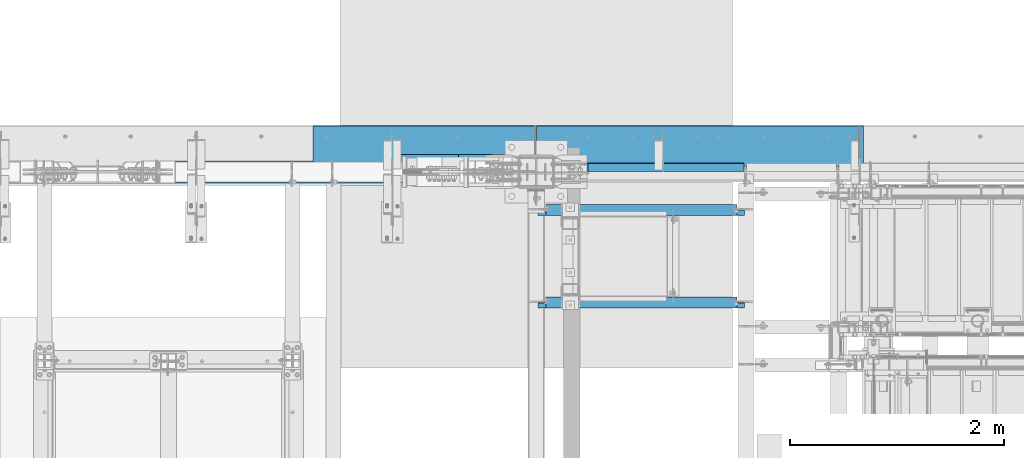
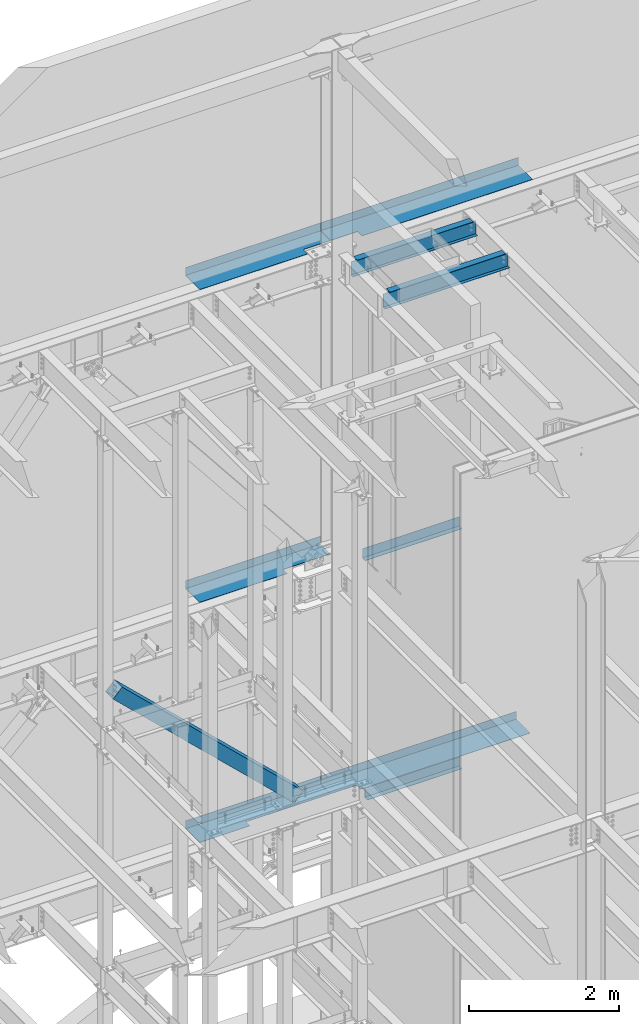
# One storey, part 790 of 1179: 9 beams, 1 member, 9 elements without a shape of their own.
"""IFC2X3 building model written with IfcOpenShell, lengths in millimetres."""

from ifc_helpers import new_model, si_unit, frame, origin_with_axes, place, context, subcontext, project, spatial, faceted_brep, material, type_object, element, aggregate, save


model = new_model("IFC2X3")

# Units and contexts
model_context = context("Model", 3, precision=1e-05, world=origin_with_axes())
body_context = subcontext(model_context, "Body", "Model", "MODEL_VIEW")
ifc_project = project(units=[si_unit("LENGTHUNIT", "METRE", prefix="MILLI"), si_unit("AREAUNIT", "SQUARE_METRE"), si_unit("VOLUMEUNIT", "CUBIC_METRE"), si_unit("MASSUNIT", "GRAM", prefix="KILO"), si_unit("TIMEUNIT", "SECOND"), si_unit("PLANEANGLEUNIT", "RADIAN"), si_unit("SOLIDANGLEUNIT", "STERADIAN"), si_unit("THERMODYNAMICTEMPERATUREUNIT", "DEGREE_CELSIUS"), si_unit("LUMINOUSINTENSITYUNIT", "LUMEN")], contexts=[model_context])

# Site, building, storey
site_placement = place(None, origin_with_axes())
site = spatial("IfcSite", under=ifc_project, at=site_placement, CompositionType="ELEMENT")
building_placement = place(site_placement, origin_with_axes())
building = spatial("IfcBuilding", under=site, at=building_placement, Name="Undefined", CompositionType="ELEMENT")
storey_placement = place(building_placement, origin_with_axes())
storey = spatial("IfcBuildingStorey", under=building, at=storey_placement, Name="Undefined", CompositionType="ELEMENT", Elevation=0.0)

# Assembly, beam
assembly_1_placement = place(storey_placement, origin_with_axes())
assembly_1 = element("IfcElementAssembly", 1, at=assembly_1_placement, inside=storey, Name="BEAM", AssemblyPlace="NOTDEFINED", PredefinedType="RIGID_FRAME")
ifc_material_1 = material(Name="STEEL/A992")
beam_type_1 = type_object("IfcBeamType", Name="W10X12", PredefinedType="NOTDEFINED")
beam_1_placement = place(assembly_1_placement, frame((16459.2, 39979.6, 12993.6875), z_axis=(0.0, 0.0, 1.0), x_axis=(1.0, 0.0, 0.0)))
beam_1 = element("IfcBeam", 2, at=beam_1_placement, type_object=beam_type_1, material=ifc_material_1, Name="BEAM", ObjectType="W10X12", context=body_context, shape_type="Brep", body=[
    faceted_brep([(76.200000190729, -2.38124999999854, 93.6624999999985), (76.200000190729, 2.38123180787079, 93.6624999999985), (15.875, 2.38124999999854, 93.6624999999985), (15.875, -2.38124999999854, 93.6624999999985), (81.0600797087754, -2.38124999999854, 94.6292299225861), (81.0600797087754, 2.38123086899577, 94.6292299225861), (85.1802561769291, -2.38124999999854, 97.3822438230636), (85.1802561769291, 2.38122819529235, 97.3822438230636), (87.9332700774066, -2.38124999999854, 101.502420291217), (87.9332700774066, 2.38122419381398, 101.502420291217), (88.8999999999942, -2.38124999999854, 106.362499809264), (88.8999999999942, 2.38121947374748, 106.362499809264), (88.8999999999942, -50.8000000000029, 125.4125), (88.8999999999942, 50.8000000000029, 125.4125), (88.8999999999942, 50.8000000000029, 120.65), (88.8999999999942, 2.38124999999854, 120.65), (88.8999999999942, -2.38124999999854, 120.65), (88.8999999999942, -50.8000000000029, 120.65), (1812.92500000026, 2.38124999999854, -120.65), (1812.92500000026, 50.8000000000029, -120.65), (142.874999999996, 50.8000000000029, -120.65), (142.874999999996, 2.38174991607229, -120.65), (15.875, -2.38124999999854, -120.65), (15.875, -50.8000000000029, -120.65), (1939.925, -50.8000000000029, -120.65), (1939.925, -2.38124999999854, -120.65), (15.875, -50.8000000000029, -125.4125), (1939.925, -50.8000000000029, -125.4125), (1812.92500000026, 50.8000000000029, -125.4125), (1812.92500000026, 2.38174991607229, -125.4125), (1939.925, 2.38174991607229, -125.4125), (15.875, 2.38174991607229, -125.4125), (142.874999999996, 2.38174991607229, -125.4125), (142.874999999996, 50.8000000000029, -125.4125), (15.875, 2.38124999999854, -120.65), (1939.925, 2.38124999999854, -120.65), (1939.925, 2.38124999999854, 93.6624999999985), (1939.925, -2.38124999999854, 93.6624999999985), (1885.94999980927, 2.38124999999854, 93.6624999999985), (1885.94999980927, -2.38124999999854, 93.6624999999985), (1881.08992029122, 2.38124999999854, 94.6292299225861), (1881.08992029122, -2.38124999999854, 94.6292299225861), (1876.96974382307, 2.38124999999854, 97.3822438230636), (1876.96974382307, -2.38124999999854, 97.3822438230636), (1874.21672992259, 2.38124999999854, 101.502420291217), (1874.21672992259, -2.38124999999854, 101.502420291217), (1873.25, 2.38124999999854, 106.362499809264), (1873.25, -2.38124999999854, 106.362499809264), (1873.25, -50.8000000000029, 125.4125), (1873.25, -50.8000000000029, 120.65), (1873.25, -2.38124999999854, 120.65), (1873.25, 2.38124999999854, 120.65), (1873.25, 50.8000000000029, 120.65), (1873.25, 50.8000000000029, 125.4125)], [[[0, 1, 2, 3]], [[4, 5, 1, 0]], [[6, 7, 5, 4]], [[8, 9, 7, 6]], [[10, 11, 9, 8]], [[12, 13, 14, 15, 11, 10, 16, 17]], [[18, 19, 20, 21]], [[22, 23, 24, 25]], [[23, 26, 27, 24]], [[28, 29, 30, 27, 26, 31, 32, 33]], [[21, 32, 31, 34]], [[20, 33, 32, 21]], [[19, 28, 33, 20]], [[18, 29, 28, 19]], [[35, 30, 29, 18]], [[25, 24, 27, 30, 35, 36, 37]], [[37, 36, 38, 39]], [[39, 38, 40, 41]], [[41, 40, 42, 43]], [[43, 42, 44, 45]], [[45, 44, 46, 47]], [[48, 49, 50, 47, 46, 51, 52, 53]], [[49, 48, 12, 17]], [[50, 49, 17, 16]], [[8, 6, 4, 0, 3, 22, 25, 37, 39, 41, 43, 45, 47, 50, 16, 10]], [[34, 31, 26, 23, 22, 3, 2]], [[51, 46, 44, 42, 40, 38, 36, 35, 18, 21, 34, 2, 1, 5, 7, 9, 11, 15]], [[52, 51, 15, 14]], [[53, 52, 14, 13]], [[48, 53, 13, 12]]]),
])
aggregate(assembly_1, [beam_1])

assembly_2_placement = place(storey_placement, origin_with_axes())
assembly_2 = element("IfcElementAssembly", 3, at=assembly_2_placement, inside=storey, Name="BEAM", AssemblyPlace="NOTDEFINED", PredefinedType="RIGID_FRAME")
beam_2_placement = place(assembly_2_placement, frame((16459.2, 40843.2, 12993.6875), z_axis=(0.0, 0.0, 1.0), x_axis=(1.0, 0.0, 0.0)))
beam_2 = element("IfcBeam", 4, at=beam_2_placement, type_object=beam_type_1, material=ifc_material_1, Name="BEAM", ObjectType="W10X12", context=body_context, shape_type="Brep", body=[
    faceted_brep([(76.200000190729, -2.38124999999854, 93.6624999999985), (76.200000190729, 2.38123180787079, 93.6624999999985), (15.875, 2.38124999999854, 93.6624999999985), (15.875, -2.38124999999854, 93.6624999999985), (81.0600797087754, -2.38124999999854, 94.6292299225861), (81.0600797087754, 2.38123086899577, 94.6292299225861), (85.1802561769291, -2.38124999999854, 97.3822438230636), (85.1802561769291, 2.38122819529235, 97.3822438230636), (87.9332700774066, -2.38124999999854, 101.502420291217), (87.9332700774066, 2.38122419381398, 101.502420291217), (88.8999999999942, -2.38124999999854, 106.362499809264), (88.8999999999942, 2.38121947374748, 106.362499809264), (88.8999999999942, -50.8000000000029, 125.4125), (88.8999999999942, 50.8000000000029, 125.4125), (88.8999999999942, 50.8000000000029, 120.65), (88.8999999999942, 2.38124999999854, 120.65), (88.8999999999942, -2.38124999999854, 120.65), (88.8999999999942, -50.8000000000029, 120.65), (1812.92500000026, 2.38124999999854, -120.65), (1812.92500000026, 50.8000000000029, -120.65), (142.874999999996, 50.8000000000029, -120.65), (142.874999999996, 2.38174991607229, -120.65), (15.875, -2.38124999999854, -120.65), (15.875, -50.8000000000029, -120.65), (1939.925, -50.8000000000029, -120.65), (1939.925, -2.38124999999854, -120.65), (15.875, -50.8000000000029, -125.4125), (1939.925, -50.8000000000029, -125.4125), (1812.92500000026, 50.8000000000029, -125.4125), (1812.92500000026, 2.38174991607229, -125.4125), (1939.925, 2.38174991607229, -125.4125), (15.875, 2.38174991607229, -125.4125), (142.874999999996, 2.38174991607229, -125.4125), (142.874999999996, 50.8000000000029, -125.4125), (15.875, 2.38124999999854, -120.65), (1939.925, 2.38124999999854, -120.65), (1939.925, 2.38124999999854, 93.6624999999985), (1939.925, -2.38124999999854, 93.6624999999985), (1885.94999980927, 2.38124999999854, 93.6624999999985), (1885.94999980927, -2.38124999999854, 93.6624999999985), (1881.08992029122, 2.38124999999854, 94.6292299225861), (1881.08992029122, -2.38124999999854, 94.6292299225861), (1876.96974382307, 2.38124999999854, 97.3822438230636), (1876.96974382307, -2.38124999999854, 97.3822438230636), (1874.21672992259, 2.38124999999854, 101.502420291217), (1874.21672992259, -2.38124999999854, 101.502420291217), (1873.25, 2.38124999999854, 106.362499809264), (1873.25, -2.38124999999854, 106.362499809264), (1873.25, -50.8000000000029, 125.4125), (1873.25, -50.8000000000029, 120.65), (1873.25, -2.38124999999854, 120.65), (1873.25, 2.38124999999854, 120.65), (1873.25, 50.8000000000029, 120.65), (1873.25, 50.8000000000029, 125.4125)], [[[0, 1, 2, 3]], [[4, 5, 1, 0]], [[6, 7, 5, 4]], [[8, 9, 7, 6]], [[10, 11, 9, 8]], [[12, 13, 14, 15, 11, 10, 16, 17]], [[18, 19, 20, 21]], [[22, 23, 24, 25]], [[23, 26, 27, 24]], [[28, 29, 30, 27, 26, 31, 32, 33]], [[21, 32, 31, 34]], [[20, 33, 32, 21]], [[19, 28, 33, 20]], [[18, 29, 28, 19]], [[35, 30, 29, 18]], [[25, 24, 27, 30, 35, 36, 37]], [[37, 36, 38, 39]], [[39, 38, 40, 41]], [[41, 40, 42, 43]], [[43, 42, 44, 45]], [[45, 44, 46, 47]], [[48, 49, 50, 47, 46, 51, 52, 53]], [[49, 48, 12, 17]], [[50, 49, 17, 16]], [[8, 6, 4, 0, 3, 22, 25, 37, 39, 41, 43, 45, 47, 50, 16, 10]], [[34, 31, 26, 23, 22, 3, 2]], [[51, 46, 44, 42, 40, 38, 36, 35, 18, 21, 34, 2, 1, 5, 7, 9, 11, 15]], [[52, 51, 15, 14]], [[53, 52, 14, 13]], [[48, 53, 13, 12]]]),
])
aggregate(assembly_2, [beam_2])

assembly_3_placement = place(storey_placement, origin_with_axes())
assembly_3 = element("IfcElementAssembly", 5, at=assembly_3_placement, inside=storey, Name="BEAM", AssemblyPlace="NOTDEFINED", PredefinedType="RIGID_FRAME")
ifc_material_2 = material(Name="STEEL/A36")
beam_type_2 = type_object("IfcBeamType", PredefinedType="NOTDEFINED")
beam_3_placement = place(assembly_3_placement, frame((17668.875, 41204.3562564863, 3933.82500614879), z_axis=(-1.0, 0.0, 0.0), x_axis=(0.0, 1.0, 0.0)))
beam_3 = element("IfcBeam", 6, at=beam_3_placement, type_object=beam_type_2, material=ifc_material_2, Name="BENT_PLATE", context=body_context, shape_type="Brep", body=[
    faceted_brep([(1.97906047105789e-09, -3.17500000000064, -727.075000000001), (-4.36557456851006e-10, -3.17500000000064, 727.075000000001), (-1.99361238628626e-09, 3.17499999999973, 727.075000000001), (4.22005541622639e-10, 3.17499999999973, -727.075000000001), (78.5812123424912, 3.17500001945837, 727.074999999844), (78.5812123435317, 3.17500001945837, -727.075000000154), (72.2312118482077, -3.17499998211406, -727.075000000143), (72.2312118471673, -3.17499998211406, 727.074999999859), (78.5812004540785, -149.224999952044, 727.074999999702), (78.5812004564286, -149.22499995068, -727.075000000295), (72.23120045408, -149.224999456733, 727.074999999717), (72.2312004564301, -149.224999455369, -727.075000000284)], [[[0, 1, 2, 3]], [[3, 2, 4, 5]], [[1, 0, 6, 7]], [[5, 4, 8, 9]], [[4, 2, 1, 7, 10, 8]], [[7, 6, 11, 10]], [[6, 0, 3, 5, 9, 11]], [[10, 11, 9, 8]]]),
])

assembly_4_placement = place(storey_placement, origin_with_axes())
assembly_4 = element("IfcElementAssembly", 7, at=assembly_4_placement, inside=storey, Name="BEAM", AssemblyPlace="NOTDEFINED", PredefinedType="RIGID_FRAME")
beam_4_placement = place(assembly_4_placement, frame((17651.4125015518, 41204.3562517714, 7845.42500611495), z_axis=(-1.0, 0.0, 0.0), x_axis=(0.0, 1.0, 0.0)))
beam_4 = element("IfcBeam", 8, at=beam_4_placement, type_object=beam_type_2, material=ifc_material_2, Name="BENT_PLATE", context=body_context, shape_type="Brep", body=[
    faceted_brep([(2.01544025912881e-09, -3.17500000000109, -744.537499999999), (-4.72937244921923e-10, -3.17500000000109, 744.537499999999), (-2.02999217435718e-09, 3.17499999999927, 744.537499999999), (4.58385329693556e-10, 3.17499999999927, -744.537499999999), (78.5812123431824, 3.17500001945882, 744.537499999846), (78.581212344252, 3.17500001945882, -744.537500000155), (72.2312118489281, -3.17499998211406, -744.53750000014), (72.2312118478585, -3.17499998211406, 744.53749999986), (78.5812004547552, -149.224999951356, 744.537499999704), (78.5812004571635, -149.224999949959, -744.537500000297), (72.2312004547566, -149.224999456044, 744.537499999715), (72.231200457165, -149.224999454647, -744.537500000282)], [[[0, 1, 2, 3]], [[3, 2, 4, 5]], [[1, 0, 6, 7]], [[5, 4, 8, 9]], [[4, 2, 1, 7, 10, 8]], [[7, 6, 11, 10]], [[6, 0, 3, 5, 9, 11]], [[10, 11, 9, 8]]]),
])
aggregate(assembly_4, [beam_4])

assembly_5_placement = place(storey_placement, origin_with_axes())
assembly_5 = element("IfcElementAssembly", 9, at=assembly_5_placement, inside=storey, Name="BEAM", AssemblyPlace="NOTDEFINED", PredefinedType="RIGID_FRAME")
beam_type_3 = type_object("IfcBeamType", PredefinedType="NOTDEFINED")
beam_5_placement = place(assembly_5_placement, frame((15417.7999999922, 41244.8379999477, 13122.275), z_axis=(-1.0, 0.0, 0.0), x_axis=(0.0, 1.0, 0.0)))
beam_5 = element("IfcBeam", 10, at=beam_5_placement, type_object=beam_type_3, material=ifc_material_2, Name="BENT_PLATE", context=body_context, shape_type="Brep", body=[
    faceted_brep([(117.474500052282, -3.17499999999927, -622.496734676753), (117.474500052282, 3.17499999999927, -622.496734676753), (117.474500052282, 3.17499999999927, -1038.225), (117.474500052282, -3.17499999999927, -1038.225), (0.0, -3.17499999999927, -622.496734676753), (0.0, 3.17499999999927, -622.496734676753), (385.762000000002, 3.17499999999927, 1038.225), (0.0, 3.17499999999927, 1038.225), (0.0, -3.17499999999927, 1038.225), (379.411999999997, -3.17499999999927, 1038.225), (379.411999999997, -130.175000000008, 1038.225), (385.762000000002, -130.175000000008, 1038.225), (385.762000000002, 3.17499999999927, -1038.225), (385.762000000002, -130.175000000008, -1038.225), (379.411999999997, -130.175000000008, -1038.225), (379.411999999997, -3.17499999999927, -1038.225)], [[[0, 1, 2, 3]], [[4, 5, 1, 0]], [[6, 7, 8, 9, 10, 11]], [[12, 6, 11, 13]], [[10, 14, 13, 11]], [[9, 15, 14, 10]], [[12, 13, 14, 15, 3, 2]], [[7, 6, 12, 2, 1, 5]], [[8, 7, 5, 4]], [[15, 9, 8, 4, 0, 3]]]),
])
aggregate(assembly_5, [beam_5])

assembly_6_placement = place(storey_placement, origin_with_axes())
assembly_6 = element("IfcElementAssembly", 11, at=assembly_6_placement, inside=storey, Name="BEAM", AssemblyPlace="NOTDEFINED", PredefinedType="RIGID_FRAME")
beam_6_placement = place(assembly_6_placement, frame((17986.375, 41244.838, 13122.275), z_axis=(-1.0, 0.0, 0.0), x_axis=(0.0, 1.0, 0.0)))
beam_6 = element("IfcBeam", 12, at=beam_6_placement, type_object=beam_type_3, material=ifc_material_2, Name="BENT_PLATE", context=body_context, shape_type="Brep", body=[
    faceted_brep([(117.474499999989, -3.17499999999927, 1108.07499992477), (117.474499999989, 3.17499999999927, 1108.07499992477), (0.0, 3.17499999999927, 1108.07499992477), (0.0, -3.17499999999927, 1108.07499992477), (117.474497999712, -3.17499999999927, 1524.0), (117.474497999712, 3.17499999999927, 1524.0), (379.411999999997, -3.17499999999927, -1524.0), (0.0, -3.17499999999927, -1524.0), (0.0, 3.17499999999927, -1524.0), (385.762000000002, 3.17499999999927, -1524.0), (385.762000000002, -130.175000000001, -1524.0), (379.411999999997, -130.175000000001, -1524.0), (385.762000000002, 3.17499999999927, 1524.0), (385.762000000002, -130.175000000001, 1524.0), (379.411999999997, -130.175000000001, 1524.0), (379.411999999997, -3.17499999999927, 1524.0)], [[[0, 1, 2, 3]], [[4, 5, 1, 0]], [[6, 7, 8, 9, 10, 11]], [[9, 12, 13, 10]], [[14, 11, 10, 13]], [[15, 6, 11, 14]], [[3, 7, 6, 15, 4, 0]], [[8, 7, 3, 2]], [[12, 9, 8, 2, 1, 5]], [[15, 14, 13, 12, 5, 4]]]),
])
aggregate(assembly_6, [beam_6])

# Beam
beam_type_4 = type_object("IfcBeamType", PredefinedType="NOTDEFINED")
beam_7_placement = place(assembly_3_placement, frame((17968.9125, 41627.425, 4235.45000610352), z_axis=(1.0, 0.0, 0.0), x_axis=(0.0, 0.0, -1.0)))
beam_7 = element("IfcBeam", 13, at=beam_7_placement, type_object=beam_type_4, material=ifc_material_2, Name="BENT_PLATE", context=body_context, shape_type="Brep", body=[
    faceted_brep([(133.350006103513, -265.11250000001, -1103.3125), (127.000006103513, -265.11250000001, -1103.3125), (127.000006103513, -265.11250000001, -1506.5375), (133.350006103513, -265.11250000001, -1506.5375), (133.350006103513, -373.062500000007, -1103.3125), (127.000006103513, -373.062500000007, -1103.3125), (0.0, 3.17500000000291, -1506.5375), (0.0, 3.17500000000291, 1506.5375), (133.350006103513, 3.17500000000291, 1506.5375), (133.350006103513, 3.17500000000291, -1506.5375), (0.0, -3.17500000000291, -1506.5375), (0.0, -3.17500000000291, 1506.5375), (127.000006103513, -3.17500000000291, -1506.5375), (127.000006103513, -3.17500000000291, 1506.5375), (127.000006103513, -373.062500000007, 1506.5375), (133.350006103513, -373.062500000007, 1506.5375)], [[[0, 1, 2, 3]], [[4, 5, 1, 0]], [[6, 7, 8, 9]], [[10, 11, 7, 6]], [[11, 10, 12, 13]], [[8, 7, 11, 13, 14, 15]], [[3, 9, 8, 15, 4, 0]], [[12, 10, 6, 9, 3, 2]], [[14, 13, 12, 2, 1, 5]], [[15, 14, 5, 4]]]),
])

aggregate(assembly_3, [beam_7, beam_3])

# Assembly, beam
assembly_7_placement = place(storey_placement, origin_with_axes())
assembly_7 = element("IfcElementAssembly", 14, at=assembly_7_placement, inside=storey, Name="BEAM", AssemblyPlace="NOTDEFINED", PredefinedType="RIGID_FRAME")
beam_8_placement = place(assembly_7_placement, frame((15417.8, 41627.425, 4235.45000610352), z_axis=(1.0, 0.0, 0.0), x_axis=(0.0, 0.0, -1.0)))
beam_8 = element("IfcBeam", 15, at=beam_8_placement, type_object=beam_type_4, material=ifc_material_2, Name="BENT_PLATE", context=body_context, shape_type="Brep", body=[
    faceted_brep([(133.350006103513, -373.062500000007, -260.658213339186), (133.350006103513, -265.11250000001, -260.658213339124), (127.000006103513, -265.11250000001, -260.658213339124), (127.000006103513, -373.062500000007, -260.658213339186), (133.350006103513, -265.112500005154, 1038.2250000002), (127.000006103513, -265.112500005154, 1038.225), (127.000006103513, -3.17500000000291, -1038.225), (0.0, -3.17500000000291, -1038.225), (0.0, 3.17500000000291, -1038.225), (133.350006103513, 3.17500000000291, -1038.225), (133.350006103513, -373.062500000007, -1038.225), (127.000006103513, -373.062500000007, -1038.225), (0.0, -3.17499999999927, 1038.225), (127.000006103513, -3.17500000000291, 1038.225), (0.0, 3.17499999999927, 1038.225), (133.350006103513, 3.17500000000291, 1038.225)], [[[0, 1, 2, 3]], [[4, 5, 2, 1]], [[6, 7, 8, 9, 10, 11]], [[12, 7, 6, 13]], [[7, 12, 14, 8]], [[8, 14, 15, 9]], [[0, 10, 9, 15, 4, 1]], [[11, 10, 0, 3]], [[13, 6, 11, 3, 2, 5]], [[15, 14, 12, 13, 5, 4]]]),
])
aggregate(assembly_7, [beam_8])

assembly_8_placement = place(storey_placement, origin_with_axes())
assembly_8 = element("IfcElementAssembly", 16, at=assembly_8_placement, inside=storey, Name="BEAM", AssemblyPlace="NOTDEFINED", PredefinedType="RIGID_FRAME")
beam_9_placement = place(assembly_8_placement, frame((15417.8, 41627.425, 8147.05000610352), z_axis=(1.0, 0.0, 0.0), x_axis=(0.0, 0.0, -1.0)))
beam_9 = element("IfcBeam", 17, at=beam_9_placement, type_object=beam_type_4, material=ifc_material_2, Name="BENT_PLATE", context=body_context, shape_type="Brep", body=[
    faceted_brep([(133.350006103513, -373.062500000007, 314.028583330155), (133.350006103513, -265.112500002368, 314.028583330217), (127.000006103513, -265.112500002368, 314.028583330217), (127.000006103513, -373.062500000007, 314.028583330155), (133.350006103513, -265.112500005154, 1038.2250000002), (127.000006103513, -265.112500005154, 1038.225), (127.000006103513, -3.17500000000291, -1038.225), (0.0, -3.17500000000291, -1038.225), (0.0, 3.17500000000291, -1038.225), (133.350006103513, 3.17500000000291, -1038.225), (133.350006103513, -373.062500000007, -1038.225), (127.000006103513, -373.062500000007, -1038.225), (0.0, -3.17499999999927, 1038.225), (127.000006103513, -3.17500000000291, 1038.225), (0.0, 3.17499999999927, 1038.225), (133.350006103513, 3.17500000000291, 1038.225)], [[[0, 1, 2, 3]], [[4, 5, 2, 1]], [[6, 7, 8, 9, 10, 11]], [[12, 7, 6, 13]], [[7, 12, 14, 8]], [[8, 14, 15, 9]], [[0, 10, 9, 15, 4, 1]], [[11, 10, 0, 3]], [[13, 6, 11, 3, 2, 5]], [[15, 14, 12, 13, 5, 4]]]),
])
aggregate(assembly_8, [beam_9])

# Assembly, member
assembly_9_placement = place(storey_placement, origin_with_axes())
assembly_9 = element("IfcElementAssembly", 18, at=assembly_9_placement, inside=storey, Name="None", AssemblyPlace="NOTDEFINED", PredefinedType="RIGID_FRAME")
member_type = type_object("IfcMemberType", Name="HSS8X8X3/16", PredefinedType="NOTDEFINED")
member_placement = place(assembly_9_placement, frame((15818.9346717473, 41198.8, 4439.89020551487), z_axis=(0.0, 1.0, 0.0), x_axis=(-0.722641857060828, 0.0, 0.691222646058184)))
member = element("IfcMember", 19, at=member_placement, type_object=member_type, material=ifc_material_1, Name="None", ObjectType="HSS8X8X3/16", context=body_context, shape_type="Brep", body=[
    faceted_brep([(-3.63797880709171e-12, 96.8374999999978, -96.8375000000015), (-3.63797880709171e-12, -96.8374999999978, -96.8375000000015), (3864.89737425295, -96.8375000001724, -96.8375000000015), (3864.89737425283, 96.8374999999396, -96.8375000000015), (-3.63797880709171e-12, -96.8374999999978, 96.8375000000015), (3864.89737425295, -96.8375000001724, 96.8375000000015), (-3.63797880709171e-12, 96.8374999999978, 96.8375000000015), (3864.89737425283, 96.8374999999396, 96.8375000000015), (-3.63797880709171e-12, 101.599999999999, -101.599999999999), (-3.63797880709171e-12, 101.599999999999, 101.599999999999), (3864.89737425282, 101.599999999942, 101.599999999999), (3864.89737425282, 101.599999999942, -101.599999999999), (0.0, -101.599999999999, 101.599999999999), (3864.89737425295, -101.600000000173, 101.599999999999), (0.0, -101.599999999999, -101.599999999999), (3864.89737425295, -101.600000000173, -101.599999999999)], [[[0, 1, 2, 3]], [[1, 4, 5, 2]], [[4, 6, 7, 5]], [[6, 0, 3, 7]], [[8, 9, 10, 11]], [[9, 12, 13, 10]], [[12, 14, 15, 13]], [[14, 8, 11, 15]], [[13, 15, 11, 10], [5, 7, 3, 2]], [[14, 12, 9, 8], [6, 4, 1, 0]]]),
])
aggregate(assembly_9, [member])

save(model, "model.ifc")
